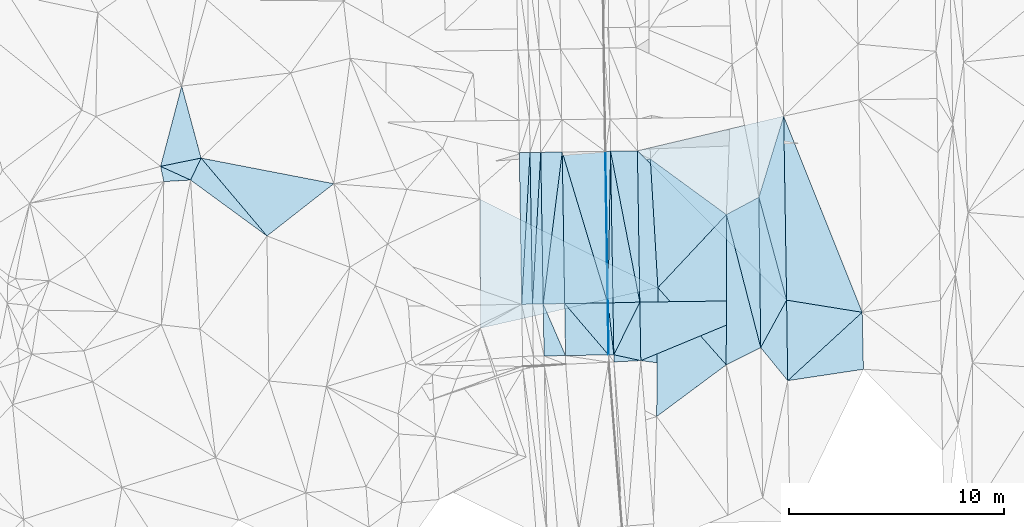
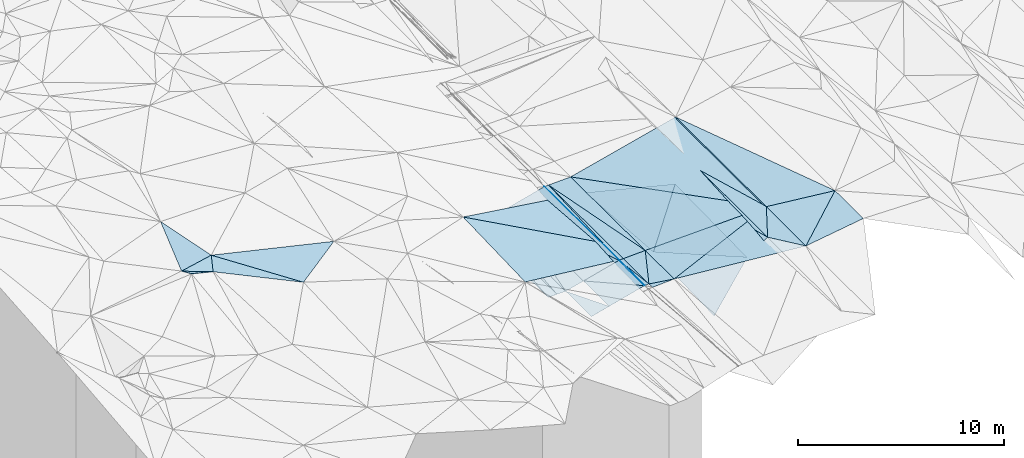
# One storey, part 5 of 275: 46 plates.
"""IFC2X3 building model written with IfcOpenShell, lengths in millimetres."""

from ifc_helpers import new_model, si_unit, frame, origin_with_axes, place, context, subcontext, project, spatial, polyline, outline, extrude, material, type_object, element, save


model = new_model("IFC2X3")

# Units and contexts
model_context = context("Model", 3, precision=1e-05, world=origin_with_axes())
body_context = subcontext(model_context, "Body", "Model", "MODEL_VIEW")
ifc_project = project(units=[si_unit("LENGTHUNIT", "METRE", prefix="MILLI"), si_unit("AREAUNIT", "SQUARE_METRE"), si_unit("VOLUMEUNIT", "CUBIC_METRE"), si_unit("MASSUNIT", "GRAM", prefix="KILO"), si_unit("TIMEUNIT", "SECOND"), si_unit("PLANEANGLEUNIT", "RADIAN"), si_unit("SOLIDANGLEUNIT", "STERADIAN"), si_unit("THERMODYNAMICTEMPERATUREUNIT", "DEGREE_CELSIUS"), si_unit("LUMINOUSINTENSITYUNIT", "LUMEN")], contexts=[model_context])

# Site, building, storey
site_placement = place(None, origin_with_axes())
site = spatial("IfcSite", under=ifc_project, at=site_placement, CompositionType="ELEMENT")
building_placement = place(site_placement, origin_with_axes())
building = spatial("IfcBuilding", under=site, at=building_placement, Name="Undefined", CompositionType="ELEMENT")
storey_placement = place(building_placement, origin_with_axes())
storey = spatial("IfcBuildingStorey", under=building, at=storey_placement, Name="Undefined", CompositionType="ELEMENT", Elevation=0.0)

# Plates
ifc_material = material()
plate_type_1 = type_object("IfcPlateType", PredefinedType="NOTDEFINED")
plate_1_placement = place(storey_placement, frame((-94927.5139132735, -9997.44010098032, 40712.4976903028), z_axis=(0.0496646425056546, 0.0175822813768752, -0.99861117892119), x_axis=(0.998632888221873, 0.0154461280542163, 0.0499376780574742)))
element("IfcPlate", 1, at=plate_1_placement, inside=storey, type_object=plate_type_1, material=ifc_material, Name="00_PR", context=body_context, shape_type="SweptSolid", body=[
    extrude(outline(polyline([(0.0, 0.0), (20.0249881744385, 1.60071067512035e-10), (18.1142177581787, 7059.302734375), (0.0, 0.0)])), frame((-8.85201319254618e-08, 2.18876761149539e-07, -0.5000001331573), z_axis=(0.0, 0.0, 1.0), x_axis=(1.0, 0.0, 0.0)), (0.0, 0.0, 1.0), 1.0),
])
plate_2_placement = place(storey_placement, frame((-94794.3388379834, -17054.528449606, 40594.868708311), z_axis=(0.049600905912721, 0.0197007283815601, -0.998574800119587), x_axis=(0.0168191860557783, -0.9996801451006, -0.0188870980318407)))
element("IfcPlate", 2, at=plate_2_placement, inside=storey, type_object=plate_type_1, material=ifc_material, Name="00_PR", context=body_context, shape_type="SweptSolid", body=[
    extrude(outline(polyline([(0.0, 0.0), (2420.7001953125, -1.29512045532465e-09), (2420.72241210938, 20.0250949859619), (0.0, 0.0)])), frame((-8.85201319254618e-08, 2.18876761149539e-07, -0.5000001331573), z_axis=(0.0, 0.0, 1.0), x_axis=(1.0, 0.0, 0.0)), (0.0, 0.0, 1.0), 1.0),
])
plate_3_placement = place(storey_placement, frame((-94794.3388147298, -17054.529509335, 40594.8686898721), z_axis=(0.0496452546452091, 0.0175819316373426, -0.998612149120524), x_axis=(-0.998614605933518, -0.0165868560484308, -0.0499374110529652)))
element("IfcPlate", 3, at=plate_3_placement, inside=storey, type_object=plate_type_1, material=ifc_material, Name="00_PR", context=body_context, shape_type="SweptSolid", body=[
    extrude(outline(polyline([(0.0, 0.0), (20.0250701904297, 1.0550138540566e-10), (10.0615901947021, 7059.31884765625), (0.0, 0.0)])), frame((-8.85201319254618e-08, 2.18876761149539e-07, -0.5000001331573), z_axis=(0.0, 0.0, 1.0), x_axis=(1.0, 0.0, 0.0)), (0.0, 0.0, 1.0), 1.0),
])
plate_4_placement = place(storey_placement, frame((-94814.3361574389, -17054.8606029937, 40593.8687089397), z_axis=(0.0496081749761739, 0.0197007840646512, -0.998574437927775), x_axis=(0.99861460593351, 0.0165868560476074, 0.0499374110534007)))
element("IfcPlate", 4, at=plate_4_placement, inside=storey, type_object=plate_type_1, material=ifc_material, Name="00_PR", context=body_context, shape_type="SweptSolid", body=[
    extrude(outline(polyline([(0.0, 0.0), (20.0250701904297, 1.0550138540566e-10), (-1.76434063911438, 2420.70703125), (0.0, 0.0)])), frame((-8.85201319254618e-08, 2.18876761149539e-07, -0.5000001331573), z_axis=(0.0, 0.0, 1.0), x_axis=(1.0, 0.0, 0.0)), (0.0, 0.0, 1.0), 1.0),
])
plate_type_2 = type_object("IfcPlateType", PredefinedType="NOTDEFINED")
plate_5_placement = place(storey_placement, frame((-87771.7186120099, -12134.0931147246, 40839.5002184108), z_axis=(0.0242745301608767, 0.0190518504289721, -0.999523773694603), x_axis=(0.292778553340211, 0.95584471710844, 0.0253297350933481)))
element("IfcPlate", 5, at=plate_5_placement, inside=storey, type_object=plate_type_2, material=ifc_material, Name="00", context=body_context, shape_type="SweptSolid", body=[
    extrude(outline(polyline([(0.0, 0.0), (3947.92919921875, 2.6775524020195e-09), (-4204.947265625, 2638.92065429688), (0.0, 0.0)])), frame((-8.85201319254618e-08, 2.18876761149539e-07, -0.5000001331573), z_axis=(0.0, 0.0, 1.0), x_axis=(1.0, 0.0, 0.0)), (0.0, 0.0, 1.0), 1.0),
])
plate_type_3 = type_object("IfcPlateType", PredefinedType="NOTDEFINED")
plate_6_placement = place(storey_placement, frame((-93314.7341041264, -17019.3097710616, 40633.4961825337), z_axis=(0.0212696233326671, 0.0171446352276068, -0.99962676265004), x_axis=(-0.999449201832803, -0.0251108320409967, -0.0216965220711243)))
element("IfcPlate", 6, at=plate_6_placement, inside=storey, type_object=plate_type_3, material=ifc_material, Name="00_PR", context=body_context, shape_type="SweptSolid", body=[
    extrude(outline(polyline([(0.0, 0.0), (1250.33862304688, 1.30603439174592e-09), (1183.66589355469, 7058.7177734375), (0.0, 0.0)])), frame((-8.85201319254618e-08, 2.18876761149539e-07, -0.5000001331573), z_axis=(0.0, 0.0, 1.0), x_axis=(1.0, 0.0, 0.0)), (0.0, 0.0, 1.0), 1.0),
])
plate_type_4 = type_object("IfcPlateType", PredefinedType="NOTDEFINED")
plate_7_placement = place(storey_placement, frame((-87685.1547520205, -19136.0037125324, 40728.5000861858), z_axis=(0.012971087999581, 0.016009824732651, -0.999787695657502), x_axis=(-0.012361203658126, 0.999797974735027, 0.0158496170256584)))
element("IfcPlate", 7, at=plate_7_placement, inside=storey, type_object=plate_type_4, material=ifc_material, Name="00", context=body_context, shape_type="SweptSolid", body=[
    extrude(outline(polyline([(0.0, 0.0), (7003.32373046875, 5.06406649947166e-09), (2194.22778320313, 1232.10363769531), (0.0, 0.0)])), frame((-8.85201319254618e-08, 2.18876761149539e-07, -0.5000001331573), z_axis=(0.0, 0.0, 1.0), x_axis=(1.0, 0.0, 0.0)), (0.0, 0.0, 1.0), 1.0),
])
plate_type_5 = type_object("IfcPlateType", PredefinedType="NOTDEFINED")
plate_8_placement = place(storey_placement, frame((-94677.5571084202, -9993.5785514712, 40724.9972017376), z_axis=(0.0227719300128915, 0.0174355504861273, -0.999588635781107), x_axis=(0.999595226999715, 0.0166582280450349, 0.0230626450735228)))
element("IfcPlate", 8, at=plate_8_placement, inside=storey, type_object=plate_type_5, material=ifc_material, Name="00_PR", context=body_context, shape_type="SweptSolid", body=[
    extrude(outline(polyline([(0.0, 0.0), (1250.33361816406, 1.16688170237467e-09), (1243.12561035156, 7048.48876953125), (0.0, 0.0)])), frame((-8.85201319254618e-08, 2.18876761149539e-07, -0.5000001331573), z_axis=(0.0, 0.0, 1.0), x_axis=(1.0, 0.0, 0.0)), (0.0, 0.0, 1.0), 1.0),
])
plate_type_6 = type_object("IfcPlateType", PredefinedType="NOTDEFINED")
plate_9_placement = place(storey_placement, frame((-98427.1213250181, -10051.5104335745, 39962.4970652688), z_axis=(-0.000259430561075232, 0.0167914220583063, -0.999858980477269), x_axis=(-0.0546059719421584, -0.998367443106328, -0.0167522050364904)))
element("IfcPlate", 9, at=plate_9_placement, inside=storey, type_object=plate_type_6, material=ifc_material, Name="00_PR", context=body_context, shape_type="SweptSolid", body=[
    extrude(outline(polyline([(0.0, 0.0), (7081.396484375, 9.45874489843845e-10), (35.0112648010254, 498.7724609375), (0.0, 0.0)])), frame((-8.85201319254618e-08, 2.18876761149539e-07, -0.5000001331573), z_axis=(0.0, 0.0, 1.0), x_axis=(1.0, 0.0, 0.0)), (0.0, 0.0, 1.0), 1.0),
])
plate_10_placement = place(storey_placement, frame((-98813.8078653934, -17121.3459938693, 39843.8680649797), z_axis=(-0.000279150864820404, 0.0167925002665653, -0.99985895705824), x_axis=(0.0546059719422181, 0.998367443106426, 0.0167522050304812)))
element("IfcPlate", 10, at=plate_10_placement, inside=storey, type_object=plate_type_6, material=ifc_material, Name="00_PR", context=body_context, shape_type="SweptSolid", body=[
    extrude(outline(polyline([(0.0, 0.0), (7081.396484375, 9.45874489843845e-10), (35.596305847168, 498.731567382813), (0.0, 0.0)])), frame((-8.85201319254618e-08, 2.18876761149539e-07, -0.5000001331573), z_axis=(0.0, 0.0, 1.0), x_axis=(1.0, 0.0, 0.0)), (0.0, 0.0, 1.0), 1.0),
])
plate_11_placement = place(storey_placement, frame((-97927.1803238894, -10043.7858674444, 39962.4970656053), z_axis=(-0.000259464610487588, 0.0167928159420258, -0.999858957058871), x_axis=(-0.0546118659669137, -0.998367097506425, -0.0167535880398004)))
element("IfcPlate", 11, at=plate_11_placement, inside=storey, type_object=plate_type_6, material=ifc_material, Name="00_PR", context=body_context, shape_type="SweptSolid", body=[
    extrude(outline(polyline([(0.0, 0.0), (7080.8115234375, 2.00816430151463e-09), (35.0146636962891, 498.773132324219), (0.0, 0.0)])), frame((-8.85201319254618e-08, 2.18876761149539e-07, -0.5000001331573), z_axis=(0.0, 0.0, 1.0), x_axis=(1.0, 0.0, 0.0)), (0.0, 0.0, 1.0), 1.0),
])
plate_12_placement = place(storey_placement, frame((-98313.8766797008, -17113.035348795, 39843.8680653271), z_axis=(-0.000279160950962552, 0.0167938929610835, -0.999858933664332), x_axis=(0.05461186596703, 0.998367097506446, 0.0167535880382275)))
element("IfcPlate", 12, at=plate_12_placement, inside=storey, type_object=plate_type_6, material=ifc_material, Name="00_PR", context=body_context, shape_type="SweptSolid", body=[
    extrude(outline(polyline([(0.0, 0.0), (7080.8115234375, 2.00816430151463e-09), (35.5987930297852, 498.730438232422), (0.0, 0.0)])), frame((-8.85201319254618e-08, 2.18876761149539e-07, -0.5000001331573), z_axis=(0.0, 0.0, 1.0), x_axis=(1.0, 0.0, 0.0)), (0.0, 0.0, 1.0), 1.0),
])
plate_type_7 = type_object("IfcPlateType", PredefinedType="NOTDEFINED")
plate_13_placement = place(storey_placement, frame((-94677.5436640621, -9993.57847805791, 40724.9976904861), z_axis=(0.0496646425056546, 0.0175822813768752, -0.99861117892119), x_axis=(-0.0165359229461328, -0.999693517580252, -0.0184237390434677)))
element("IfcPlate", 13, at=plate_13_placement, inside=storey, type_object=plate_type_7, material=ifc_material, Name="00_PR", context=body_context, shape_type="SweptSolid", body=[
    extrude(outline(polyline([(0.0, 0.0), (7063.11572265625, -4.17639967054129e-09), (7.56590986251831, 230.163101196289), (0.0, 0.0)])), frame((-8.85201319254618e-08, 2.18876761149539e-07, -0.5000001331573), z_axis=(0.0, 0.0, 1.0), x_axis=(1.0, 0.0, 0.0)), (0.0, 0.0, 1.0), 1.0),
])
plate_14_placement = place(storey_placement, frame((-94794.3388147298, -17054.529509335, 40594.8686898721), z_axis=(0.0496452546452091, 0.0175819316373426, -0.998612149120524), x_axis=(0.0165359229469651, 0.999693517580248, 0.0184237390429186)))
element("IfcPlate", 14, at=plate_14_placement, inside=storey, type_object=plate_type_7, material=ifc_material, Name="00_PR", context=body_context, shape_type="SweptSolid", body=[
    extrude(outline(polyline([(0.0, 0.0), (7063.11572265625, -4.17639967054129e-09), (7.83636379241943, 230.154647827148), (0.0, 0.0)])), frame((-8.85201319254618e-08, 2.18876761149539e-07, -0.5000001331573), z_axis=(0.0, 0.0, 1.0), x_axis=(1.0, 0.0, 0.0)), (0.0, 0.0, 1.0), 1.0),
])
plate_15_placement = place(storey_placement, frame((-94794.3388379834, -17054.528449606, 40594.868708311), z_axis=(0.0496081749761739, 0.0197007840646512, -0.998574437927775), x_axis=(0.998614375266631, 0.0166005750452949, 0.0499374650838619)))
element("IfcPlate", 15, at=plate_15_placement, inside=storey, type_object=plate_type_7, material=ifc_material, Name="00_PR", context=body_context, shape_type="SweptSolid", body=[
    extrude(outline(polyline([(0.0, 0.0), (230.287994384766, 9.60426405072212e-10), (228.489288330078, 2420.60668945313), (0.0, 0.0)])), frame((-8.85201319254618e-08, 2.18876761149539e-07, -0.5000001331573), z_axis=(0.0, 0.0, 1.0), x_axis=(1.0, 0.0, 0.0)), (0.0, 0.0, 1.0), 1.0),
])
plate_type_8 = type_object("IfcPlateType", PredefinedType="NOTDEFINED")
plate_16_placement = place(storey_placement, frame((-94523.6584671355, -19470.5385375055, 40560.6487085248), z_axis=(0.049600905912721, 0.0197007283815601, -0.998574800119587), x_axis=(-0.998607579908354, -0.0170036750407609, -0.0499377250652158)))
element("IfcPlate", 16, at=plate_16_placement, inside=storey, type_object=plate_type_8, material=ifc_material, Name="00_PR", context=body_context, shape_type="SweptSolid", body=[
    extrude(outline(polyline([(0.0, 0.0), (230.286819458008, -2.61934474110603e-10), (227.513549804688, 2420.69848632813), (0.0, 0.0)])), frame((-8.85201319254618e-08, 2.18876761149539e-07, -0.5000001331573), z_axis=(0.0, 0.0, 1.0), x_axis=(1.0, 0.0, 0.0)), (0.0, 0.0, 1.0), 1.0),
])
plate_type_9 = type_object("IfcPlateType", PredefinedType="NOTDEFINED")
plate_17_placement = place(storey_placement, frame((-96927.1789059125, -10028.3358508624, 40212.5119901677), z_axis=(0.24222010810527, 0.0201813119040169, -0.970011409149039), x_axis=(-0.124158606985551, -0.990918786327561, -0.0516197560486351)))
element("IfcPlate", 17, at=plate_17_placement, inside=storey, type_object=plate_type_9, material=ifc_material, Name="00_PR", context=body_context, shape_type="SweptSolid", body=[
    extrude(outline(polyline([(0.0, 0.0), (7141.23876953125, 8.94942786544561e-09), (152.356704711914, 1019.45397949219), (0.0, 0.0)])), frame((-8.85201319254618e-08, 2.18876761149539e-07, -0.5000001331573), z_axis=(0.0, 0.0, 1.0), x_axis=(1.0, 0.0, 0.0)), (0.0, 0.0, 1.0), 1.0),
])
plate_18_placement = place(storey_placement, frame((-97813.8251626406, -17104.7234150204, 39843.8829878264), z_axis=(0.242202047176146, 0.0201838400435325, -0.970015866336619), x_axis=(0.124158606987489, 0.990918786326507, 0.0516197560642046)))
element("IfcPlate", 18, at=plate_18_placement, inside=storey, type_object=plate_type_9, material=ifc_material, Name="00_PR", context=body_context, shape_type="SweptSolid", body=[
    extrude(outline(polyline([(0.0, 0.0), (7141.23876953125, 8.94942786544561e-09), (153.516799926758, 1019.28094482422), (0.0, 0.0)])), frame((-8.85201319254618e-08, 2.18876761149539e-07, -0.5000001331573), z_axis=(0.0, 0.0, 1.0), x_axis=(1.0, 0.0, 0.0)), (0.0, 0.0, 1.0), 1.0),
])
plate_type_10 = type_object("IfcPlateType", PredefinedType="NOTDEFINED")
plate_19_placement = place(storey_placement, frame((-94814.2398540655, -17054.8603581597, 40593.8829899864), z_axis=(0.24221984203892, 0.0201894384800183, -0.970011306478694), x_axis=(-0.287582514168611, 0.956348260391297, -0.051906670004923)))
element("IfcPlate", 19, at=plate_19_placement, inside=storey, type_object=plate_type_10, material=ifc_material, Name="00_PR", context=body_context, shape_type="SweptSolid", body=[
    extrude(outline(polyline([(0.0, 0.0), (7347.24462890625, -1.74622982740402e-10), (6775.7431640625, 1980.75390625), (0.0, 0.0)])), frame((-8.85201319254618e-08, 2.18876761149539e-07, -0.5000001331573), z_axis=(0.0, 0.0, 1.0), x_axis=(1.0, 0.0, 0.0)), (0.0, 0.0, 1.0), 1.0),
])
plate_20_placement = place(storey_placement, frame((-96813.9627872471, -17088.1021274516, 40093.882987611), z_axis=(0.242202047176146, 0.0201838400435325, -0.970015866336619), x_axis=(-0.0160324850557786, 0.999730340152199, 0.0167990000328644)))
element("IfcPlate", 20, at=plate_20_placement, inside=storey, type_object=plate_type_10, material=ifc_material, Name="00_PR", context=body_context, shape_type="SweptSolid", body=[
    extrude(outline(polyline([(0.0, 0.0), (7061.67041015625, -8.55652615427971e-09), (9.57177448272705, 2061.52978515625), (0.0, 0.0)])), frame((-8.85201319254618e-08, 2.18876761149539e-07, -0.5000001331573), z_axis=(0.0, 0.0, 1.0), x_axis=(1.0, 0.0, 0.0)), (0.0, 0.0, 1.0), 1.0),
])
plate_type_11 = type_object("IfcPlateType", PredefinedType="NOTDEFINED")
plate_21_placement = place(storey_placement, frame((-96773.236089489, -19508.8391376709, 40048.1630050775), z_axis=(0.242149018996751, 0.0223907494926034, -0.969980673485854), x_axis=(-0.970001948421438, -0.0165145060523619, -0.2425355461545)))
element("IfcPlate", 21, at=plate_21_placement, inside=storey, type_object=plate_type_11, material=ifc_material, Name="00_PR", context=body_context, shape_type="SweptSolid", body=[
    extrude(outline(polyline([(0.0, 0.0), (1030.77673339844, -2.18278728425503e-09), (1019.2158203125, 2421.88623046875), (0.0, 0.0)])), frame((-8.85201319254618e-08, 2.18876761149539e-07, -0.5000001331573), z_axis=(0.0, 0.0, 1.0), x_axis=(1.0, 0.0, 0.0)), (0.0, 0.0, 1.0), 1.0),
])
plate_type_12 = type_object("IfcPlateType", PredefinedType="NOTDEFINED")
plate_22_placement = place(storey_placement, frame((-94773.5255924294, -19474.7926792783, 40548.1630065765), z_axis=(0.242155922878609, 0.0224000517897405, -0.969978735176512), x_axis=(-0.643122440322688, 0.752257875315885, -0.143183853065288)))
element("IfcPlate", 22, at=plate_22_placement, inside=storey, type_object=plate_type_12, material=ifc_material, Name="00_PR", context=body_context, shape_type="SweptSolid", body=[
    extrude(outline(polyline([(0.0, 0.0), (3172.7041015625, 1.39989424496889e-08), (1840.05187988281, 1572.90649414063), (0.0, 0.0)])), frame((-8.85201319254618e-08, 2.18876761149539e-07, -0.5000001331573), z_axis=(0.0, 0.0, 1.0), x_axis=(1.0, 0.0, 0.0)), (0.0, 0.0, 1.0), 1.0),
])
plate_23_placement = place(storey_placement, frame((-94773.5255924294, -19474.7926792783, 40548.1630065765), z_axis=(0.242148990139528, 0.022393768323021, -0.969980610999365), x_axis=(-0.970001948421438, -0.0165145060523619, -0.2425355461545)))
element("IfcPlate", 23, at=plate_23_placement, inside=storey, type_object=plate_type_12, material=ifc_material, Name="00_PR", context=body_context, shape_type="SweptSolid", body=[
    extrude(outline(polyline([(0.0, 0.0), (2061.55322265625, 1.61162461154163e-09), (2049.99096679688, 2421.48461914063), (0.0, 0.0)])), frame((-8.85201319254618e-08, 2.18876761149539e-07, -0.5000001331573), z_axis=(0.0, 0.0, 1.0), x_axis=(1.0, 0.0, 0.0)), (0.0, 0.0, 1.0), 1.0),
])
plate_type_13 = type_object("IfcPlateType", PredefinedType="NOTDEFINED")
plate_24_placement = place(storey_placement, frame((-93314.734132438, -17019.3087215414, 40633.4962011352), z_axis=(0.0212160963871107, 0.0192430552473553, -0.999589706869193), x_axis=(-0.442168632915472, -0.896536106934844, -0.0266441180709085)))
element("IfcPlate", 24, at=plate_24_placement, inside=storey, type_object=plate_type_13, material=ifc_material, Name="00_PR", context=body_context, shape_type="SweptSolid", body=[
    extrude(outline(polyline([(0.0, 0.0), (2734.11181640625, 4.72937244921923e-09), (581.427429199219, 1106.927734375), (0.0, 0.0)])), frame((-8.85201319254618e-08, 2.18876761149539e-07, -0.5000001331573), z_axis=(0.0, 0.0, 1.0), x_axis=(1.0, 0.0, 0.0)), (0.0, 0.0, 1.0), 1.0),
])
plate_type_14 = type_object("IfcPlateType", PredefinedType="NOTDEFINED")
plate_25_placement = place(storey_placement, frame((-86615.8503220148, -8360.48588716164, 40939.5002167048), z_axis=(0.0227406805688082, 0.0190282746567605, -0.999560296435815), x_axis=(0.0158102400401454, -0.999700665509403, -0.0186712530358977)))
element("IfcPlate", 25, at=plate_25_placement, inside=storey, type_object=plate_type_14, material=ifc_material, Name="00_PR", context=body_context, shape_type="SweptSolid", body=[
    extrude(outline(polyline([(0.0, 0.0), (8569.3232421875, 4.23460733145475e-09), (1507.55004882813, 6838.33740234375), (0.0, 0.0)])), frame((-8.85201319254618e-08, 2.18876761149539e-07, -0.5000001331573), z_axis=(0.0, 0.0, 1.0), x_axis=(1.0, 0.0, 0.0)), (0.0, 0.0, 1.0), 1.0),
])
plate_type_15 = type_object("IfcPlateType", PredefinedType="NOTDEFINED")
plate_26_placement = place(storey_placement, frame((-86480.3681534835, -16927.2436516933, 40779.5002035167), z_axis=(0.020966277356495, 0.0196990023632554, -0.99958609660184), x_axis=(0.013467130046742, -0.999720726872377, -0.0194191830433495)))
element("IfcPlate", 26, at=plate_26_placement, inside=storey, type_object=plate_type_15, material=ifc_material, Name="00_PR", context=body_context, shape_type="SweptSolid", body=[
    extrude(outline(polyline([(0.0, 0.0), (3750.82739257813, -6.38829078525305e-09), (2726.6884765625, 6827.330078125), (0.0, 0.0)])), frame((-8.85201319254618e-08, 2.18876761149539e-07, -0.5000001331573), z_axis=(0.0, 0.0, 1.0), x_axis=(1.0, 0.0, 0.0)), (0.0, 0.0, 1.0), 1.0),
])
plate_type_16 = type_object("IfcPlateType", PredefinedType="NOTDEFINED")
plate_27_placement = place(storey_placement, frame((-94523.6728040041, -19470.5386928619, 40560.6481992617), z_axis=(0.0209177758270849, 0.0193902882554067, -0.999593148924011), x_axis=(0.442168632916119, 0.896536106934431, 0.0266441180740539)))
element("IfcPlate", 27, at=plate_27_placement, inside=storey, type_object=plate_type_16, material=ifc_material, Name="00_PR", context=body_context, shape_type="SweptSolid", body=[
    extrude(outline(polyline([(0.0, 0.0), (2734.11181640625, 4.72937244921923e-09), (311.757507324219, 1245.65710449219), (0.0, 0.0)])), frame((-8.85201319254618e-08, 2.18876761149539e-07, -0.5000001331573), z_axis=(0.0, 0.0, 1.0), x_axis=(1.0, 0.0, 0.0)), (0.0, 0.0, 1.0), 1.0),
])
plate_type_17 = type_object("IfcPlateType", PredefinedType="NOTDEFINED")
plate_28_placement = place(storey_placement, frame((-93268.8580930898, -19742.2995269097, 40581.6351547084), z_axis=(0.0200312588347861, 0.0152900005586888, -0.99968243185144), x_axis=(-0.998601889002296, -0.0486165850424695, -0.0207531910764391)))
element("IfcPlate", 28, at=plate_28_placement, inside=storey, type_object=plate_type_17, material=ifc_material, Name="00_PR", context=body_context, shape_type="SweptSolid", body=[
    extrude(outline(polyline([(0.0, 0.0), (1250.89196777344, 8.7784428615123e-09), (1240.28430175781, 332.4892578125), (0.0, 0.0)])), frame((-8.85201319254618e-08, 2.18876761149539e-07, -0.5000001331573), z_axis=(0.0, 0.0, 1.0), x_axis=(1.0, 0.0, 0.0)), (0.0, 0.0, 1.0), 1.0),
])
plate_type_18 = type_object("IfcPlateType", PredefinedType="NOTDEFINED")
plate_29_placement = place(storey_placement, frame((-93268.8575598732, -19742.2974752916, 40581.6352011039), z_axis=(0.0210931955176974, 0.0193931723338027, -0.999589406691409), x_axis=(-0.016842451048688, 0.999676863155087, 0.0190394620480308)))
element("IfcPlate", 29, at=plate_29_placement, inside=storey, type_object=plate_type_18, material=ifc_material, Name="00_PR", context=body_context, shape_type="SweptSolid", body=[
    extrude(outline(polyline([(0.0, 0.0), (2723.86889648438, 4.05998434871435e-09), (2703.57641601563, 6836.51513671875), (0.0, 0.0)])), frame((-8.85201319254618e-08, 2.18876761149539e-07, -0.5000001331573), z_axis=(0.0, 0.0, 1.0), x_axis=(1.0, 0.0, 0.0)), (0.0, 0.0, 1.0), 1.0),
])
plate_type_19 = type_object("IfcPlateType", PredefinedType="NOTDEFINED")
plate_30_placement = place(storey_placement, frame((-93314.7341766303, -17019.3096382562, 40633.4961833554), z_axis=(0.0211206825484442, 0.0174096978667355, -0.999625339409159), x_axis=(-0.0160312630394873, 0.999725722667252, 0.0170727280421086)))
element("IfcPlate", 30, at=plate_30_placement, inside=storey, type_object=plate_type_19, material=ifc_material, Name="00_PR", context=body_context, shape_type="SweptSolid", body=[
    extrude(outline(polyline([(0.0, 0.0), (7048.49267578125, -9.53150447458029e-09), (-15.0312442779541, 6836.52880859375), (0.0, 0.0)])), frame((-8.85201319254618e-08, 2.18876761149539e-07, -0.5000001331573), z_axis=(0.0, 0.0, 1.0), x_axis=(1.0, 0.0, 0.0)), (0.0, 0.0, 1.0), 1.0),
])
plate_type_20 = type_object("IfcPlateType", PredefinedType="NOTDEFINED")
plate_31_placement = place(storey_placement, frame((-110673.896348879, -13940.645552376, 42959.5071330722), z_axis=(0.0396597689191871, 0.16392659757681, -0.985674983620954), x_axis=(-0.805099804589659, 0.589495657664741, 0.0656443009263372)))
element("IfcPlate", 31, at=plate_31_placement, inside=storey, type_object=plate_type_20, material=ifc_material, Name="00", context=body_context, shape_type="SweptSolid", body=[
    extrude(outline(polyline([(0.0, 0.0), (4417.74853515625, -1.80443748831749e-08), (4641.82177734375, 1128.31335449219), (0.0, 0.0)])), frame((-8.85201319254618e-08, 2.18876761149539e-07, -0.5000001331573), z_axis=(0.0, 0.0, 1.0), x_axis=(1.0, 0.0, 0.0)), (0.0, 0.0, 1.0), 1.0),
])
plate_type_21 = type_object("IfcPlateType", PredefinedType="NOTDEFINED")
plate_32_placement = place(storey_placement, frame((-87685.1190963734, -19136.0042168106, 40728.5018231171), z_axis=(0.084287590972814, 0.0150086843158135, -0.996328430490221), x_axis=(-0.891424389834467, -0.445665582513465, -0.082126401182455)))
element("IfcPlate", 32, at=plate_32_placement, inside=storey, type_object=plate_type_21, material=ifc_material, Name="00", context=body_context, shape_type="SweptSolid", body=[
    extrude(outline(polyline([(0.0, 0.0), (1802.10021972656, -1.51703716255724e-09), (-1330.44934082031, 6254.5048828125), (0.0, 0.0)])), frame((-8.85201319254618e-08, 2.18876761149539e-07, -0.5000001331573), z_axis=(0.0, 0.0, 1.0), x_axis=(1.0, 0.0, 0.0)), (0.0, 0.0, 1.0), 1.0),
])
plate_type_22 = type_object("IfcPlateType", PredefinedType="NOTDEFINED")
plate_33_placement = place(storey_placement, frame((-114230.650649034, -11336.3900732984, 43249.5089257462), z_axis=(-0.0123656071304043, 0.188008725106521, -0.982089512745207), x_axis=(-0.905644851004895, 0.414223069320916, 0.0907008968570927)))
element("IfcPlate", 33, at=plate_33_placement, inside=storey, type_object=plate_type_22, material=ifc_material, Name="00", context=body_context, shape_type="SweptSolid", body=[
    extrude(outline(polyline([(0.0, 0.0), (1543.53491210938, -9.01491148397326e-09), (0.25914540886879, 1150.34777832031), (0.0, 0.0)])), frame((-8.85201319254618e-08, 2.18876761149539e-07, -0.5000001331573), z_axis=(0.0, 0.0, 1.0), x_axis=(1.0, 0.0, 0.0)), (0.0, 0.0, 1.0), 1.0),
])
plate_type_23 = type_object("IfcPlateType", PredefinedType="NOTDEFINED")
plate_34_placement = place(storey_placement, frame((-115478.765419466, -11407.2996509024, 43599.5418045746), z_axis=(-0.238786283134742, -0.321429308641323, -0.916331987072947), x_axis=(-0.198416171613083, 0.939871001334654, -0.27798115708192)))
element("IfcPlate", 34, at=plate_34_placement, inside=storey, type_object=plate_type_23, material=ifc_material, Name="00", context=body_context, shape_type="SweptSolid", body=[
    extrude(outline(polyline([(0.0, 0.0), (755.446899414063, -4.94765117764473e-10), (-83.9238357543945, 1295.35974121094), (0.0, 0.0)])), frame((-8.85201319254618e-08, 2.18876761149539e-07, -0.5000001331573), z_axis=(0.0, 0.0, 1.0), x_axis=(1.0, 0.0, 0.0)), (0.0, 0.0, 1.0), 1.0),
])
plate_type_24 = type_object("IfcPlateType", PredefinedType="NOTDEFINED")
plate_35_placement = place(storey_placement, frame((-82961.2685134044, -17492.5925247087, 40839.5001792297), z_axis=(0.0163837913297285, 0.0229616138981685, -0.999602088667714), x_axis=(0.021752486645973, -0.999507847580795, -0.0226029190398581)))
element("IfcPlate", 35, at=plate_35_placement, inside=storey, type_object=plate_type_24, material=ifc_material, Name="00", context=body_context, shape_type="SweptSolid", body=[
    extrude(outline(polyline([(0.0, 0.0), (2654.5244140625, -8.73114913702011e-11), (3110.34985351563, 3537.55883789063), (0.0, 0.0)])), frame((-8.85201319254618e-08, 2.18876761149539e-07, -0.5000001331573), z_axis=(0.0, 0.0, 1.0), x_axis=(1.0, 0.0, 0.0)), (0.0, 0.0, 1.0), 1.0),
])
plate_type_25 = type_object("IfcPlateType", PredefinedType="NOTDEFINED")
plate_36_placement = place(storey_placement, frame((-86429.8618508504, -20677.0238699411, 40709.5000831334), z_axis=(0.00791017368703699, 0.0187704470175895, -0.999792528213229), x_axis=(-0.631537733446589, 0.775286217514032, 0.00955887890552035)))
element("IfcPlate", 36, at=plate_36_placement, inside=storey, type_object=plate_type_25, material=ifc_material, Name="00", context=body_context, shape_type="SweptSolid", body=[
    extrude(outline(polyline([(0.0, 0.0), (1987.68078613281, -8.96397978067398e-09), (2939.72241210938, 2329.44873046875), (0.0, 0.0)])), frame((-8.85201319254618e-08, 2.18876761149539e-07, -0.5000001331573), z_axis=(0.0, 0.0, 1.0), x_axis=(1.0, 0.0, 0.0)), (0.0, 0.0, 1.0), 1.0),
])
plate_type_26 = type_object("IfcPlateType", PredefinedType="NOTDEFINED")
plate_37_placement = place(storey_placement, frame((-114645.448555726, -6960.4932026507, 43709.5017112935), z_axis=(0.00950403485780992, 0.0828410379071104, -0.996517453815985), x_axis=(0.259151651602033, -0.962717468835139, -0.0775596330032736)))
element("IfcPlate", 37, at=plate_37_placement, inside=storey, type_object=plate_type_26, material=ifc_material, Name="00", context=body_context, shape_type="SweptSolid", body=[
    extrude(outline(polyline([(0.0, 0.0), (3481.1923828125, 2.66300048679113e-09), (3367.3232421875, 1921.46655273438), (0.0, 0.0)])), frame((-8.85201319254618e-08, 2.18876761149539e-07, -0.5000001331573), z_axis=(0.0, 0.0, 1.0), x_axis=(1.0, 0.0, 0.0)), (0.0, 0.0, 1.0), 1.0),
])
plate_type_27 = type_object("IfcPlateType", PredefinedType="NOTDEFINED")
plate_38_placement = place(storey_placement, frame((-107563.228486613, -11504.8944202385, 42819.5027486548), z_axis=(-0.0888855452134232, 0.0563578223073723, -0.994446155262759), x_axis=(-0.786849117701369, -0.616128573537394, 0.0354125238207261)))
element("IfcPlate", 38, at=plate_38_placement, inside=storey, type_object=plate_type_27, material=ifc_material, Name="00", context=body_context, shape_type="SweptSolid", body=[
    extrude(outline(polyline([(0.0, 0.0), (3953.40356445313, 2.04745447263122e-08), (4149.74072265625, 4772.9501953125), (0.0, 0.0)])), frame((-8.85201319254618e-08, 2.18876761149539e-07, -0.5000001331573), z_axis=(0.0, 0.0, 1.0), x_axis=(1.0, 0.0, 0.0)), (0.0, 0.0, 1.0), 1.0),
])
plate_type_28 = type_object("IfcPlateType", PredefinedType="NOTDEFINED")
plate_39_placement = place(storey_placement, frame((-92473.2277632091, -16348.0015212353, 39833.5149947741), z_axis=(0.242663106464716, 0.0157126037732901, -0.969983366271586), x_axis=(-0.0586460055256768, 0.998277715898932, 0.00149932501276536)))
element("IfcPlate", 39, at=plate_39_placement, inside=storey, type_object=plate_type_28, material=ifc_material, Name="00", context=body_context, shape_type="SweptSolid", body=[
    extrude(outline(polyline([(0.0, 0.0), (6002.7001953125, -2.48837750405073e-09), (3211.55444335938, 3488.08032226563), (0.0, 0.0)])), frame((-8.85201319254618e-08, 2.18876761149539e-07, -0.5000001331573), z_axis=(0.0, 0.0, 1.0), x_axis=(1.0, 0.0, 0.0)), (0.0, 0.0, 1.0), 1.0),
])
plate_type_29 = type_object("IfcPlateType", PredefinedType="NOTDEFINED")
plate_40_placement = place(storey_placement, frame((-86429.8557624668, -20677.023788641, 40709.5001707047), z_axis=(0.0200846442961595, 0.0189312088952549, -0.999619035629705), x_axis=(-0.0134673246622425, 0.999735130116756, 0.0186628180314224)))
element("IfcPlate", 40, at=plate_40_placement, inside=storey, type_object=plate_type_29, material=ifc_material, Name="00", context=body_context, shape_type="SweptSolid", body=[
    extrude(outline(polyline([(0.0, 0.0), (3750.77319335938, 3.91446519643068e-09), (3139.29931640625, 3511.89404296875), (0.0, 0.0)])), frame((-8.85201319254618e-08, 2.18876761149539e-07, -0.5000001331573), z_axis=(0.0, 0.0, 1.0), x_axis=(1.0, 0.0, 0.0)), (0.0, 0.0, 1.0), 1.0),
])
plate_type_30 = type_object("IfcPlateType", PredefinedType="NOTDEFINED")
plate_41_placement = place(storey_placement, frame((-89284.0131143002, -12944.8250017052, 40686.5021611592), z_axis=(0.0916591871172699, 0.0169170543986396, -0.995646727854551), x_axis=(0.877862576198153, 0.470605690735562, 0.0888120552517857)))
element("IfcPlate", 41, at=plate_41_placement, inside=storey, type_object=plate_type_30, material=ifc_material, Name="00", context=body_context, shape_type="SweptSolid", body=[
    extrude(outline(polyline([(0.0, 0.0), (1722.73913574219, -1.12158886622638e-08), (-1506.26110839844, 6214.50732421875), (0.0, 0.0)])), frame((-8.85201319254618e-08, 2.18876761149539e-07, -0.5000001331573), z_axis=(0.0, 0.0, 1.0), x_axis=(1.0, 0.0, 0.0)), (0.0, 0.0, 1.0), 1.0),
])
plate_type_31 = type_object("IfcPlateType", PredefinedType="NOTDEFINED")
plate_42_placement = place(storey_placement, frame((-86615.8517002797, -8360.4858740688, 40939.5001715926), z_axis=(0.0200936641053912, 0.0189874852603085, -0.999617786989762), x_axis=(0.371524108675219, -0.928367647910772, -0.0101659719508197)))
element("IfcPlate", 42, at=plate_42_placement, inside=storey, type_object=plate_type_31, material=ifc_material, Name="00", context=body_context, shape_type="SweptSolid", body=[
    extrude(outline(polyline([(0.0, 0.0), (9836.7373046875, -6.53380993753672e-09), (8005.06298828125, 3058.14794921875), (0.0, 0.0)])), frame((-8.85201319254618e-08, 2.18876761149539e-07, -0.5000001331573), z_axis=(0.0, 0.0, 1.0), x_axis=(1.0, 0.0, 0.0)), (0.0, 0.0, 1.0), 1.0),
])
plate_type_32 = type_object("IfcPlateType", PredefinedType="NOTDEFINED")
plate_43_placement = place(storey_placement, frame((-89291.475308434, -19939.1385208711, 40580.5151453459), z_axis=(0.243947896281569, 0.0144327575595278, -0.969680936911222), x_axis=(-0.655261319378295, 0.739571433582455, -0.153839845148807)))
element("IfcPlate", 43, at=plate_43_placement, inside=storey, type_object=plate_type_32, material=ifc_material, Name="00", context=body_context, shape_type="SweptSolid", body=[
    extrude(outline(polyline([(0.0, 0.0), (4855.69921875, -7.52334017306566e-09), (5151.546875, 4732.15185546875), (0.0, 0.0)])), frame((-8.85201319254618e-08, 2.18876761149539e-07, -0.5000001331573), z_axis=(0.0, 0.0, 1.0), x_axis=(1.0, 0.0, 0.0)), (0.0, 0.0, 1.0), 1.0),
])
plate_type_33 = type_object("IfcPlateType", PredefinedType="NOTDEFINED")
plate_44_placement = place(storey_placement, frame((-92531.607681662, -22346.8674146359, 39711.5155548117), z_axis=(0.246992211842436, 0.0173001627908254, -0.968863020068674), x_axis=(0.00972971246391802, 0.999745938799108, 0.0203320080183769)))
element("IfcPlate", 44, at=plate_44_placement, inside=storey, type_object=plate_type_33, material=ifc_material, Name="00", context=body_context, shape_type="SweptSolid", body=[
    extrude(outline(polyline([(0.0, 0.0), (6000.39111328125, -4.30736690759659e-09), (2456.31274414063, 3319.23510742188), (0.0, 0.0)])), frame((-8.85201319254618e-08, 2.18876761149539e-07, -0.5000001331573), z_axis=(0.0, 0.0, 1.0), x_axis=(1.0, 0.0, 0.0)), (0.0, 0.0, 1.0), 1.0),
])
plate_type_34 = type_object("IfcPlateType", PredefinedType="NOTDEFINED")
plate_45_placement = place(storey_placement, frame((-100738.265046007, -18234.934819276, 42103.5191021942), z_axis=(-0.271823380828278, 0.0335795621898022, -0.96176112555989), x_axis=(-0.0026371205590071, 0.999361296315837, 0.0356376910178885)))
element("IfcPlate", 45, at=plate_45_placement, inside=storey, type_object=plate_type_34, material=ifc_material, Name="00", context=body_context, shape_type="SweptSolid", body=[
    extrude(outline(polyline([(0.0, 0.0), (6004.87841796875, 3.53611540049315e-09), (1783.04431152344, 8593.06640625), (0.0, 0.0)])), frame((-8.85201319254618e-08, 2.18876761149539e-07, -0.5000001331573), z_axis=(0.0, 0.0, 1.0), x_axis=(1.0, 0.0, 0.0)), (0.0, 0.0, 1.0), 1.0),
])
plate_type_35 = type_object("IfcPlateType", PredefinedType="NOTDEFINED")
plate_46_placement = place(storey_placement, frame((-92825.5307549794, -10355.655353712, 39842.5222272594), z_axis=(-0.294516338812717, -0.0158669070977883, -0.955514713351659), x_axis=(0.0586460055919503, -0.99827771589509, -0.00149932497847829)))
element("IfcPlate", 46, at=plate_46_placement, inside=storey, type_object=plate_type_35, material=ifc_material, Name="00", context=body_context, shape_type="SweptSolid", body=[
    extrude(outline(polyline([(0.0, 0.0), (6002.7001953125, -2.48837750405073e-09), (1406.33569335938, 8398.697265625), (0.0, 0.0)])), frame((-8.85201319254618e-08, 2.18876761149539e-07, -0.5000001331573), z_axis=(0.0, 0.0, 1.0), x_axis=(1.0, 0.0, 0.0)), (0.0, 0.0, 1.0), 1.0),
])

save(model, "model.ifc")
